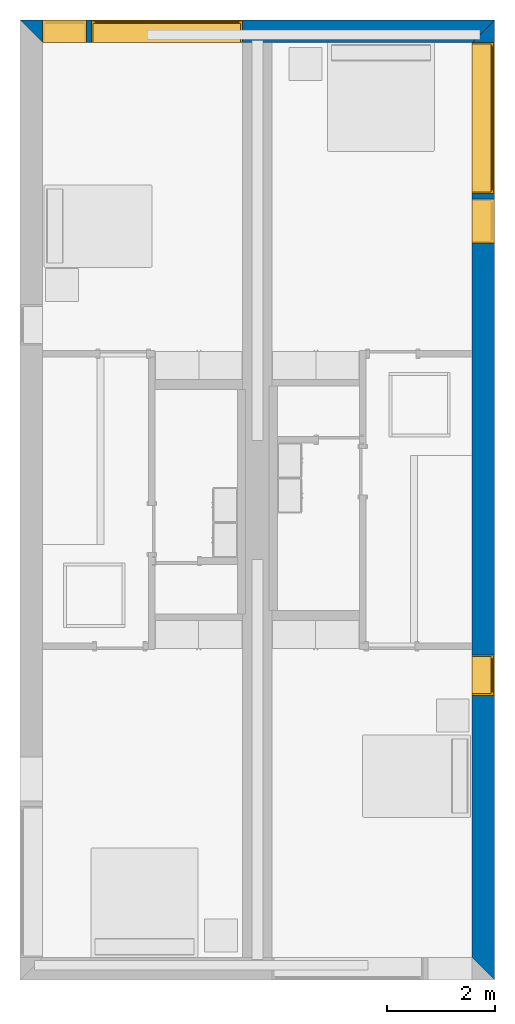
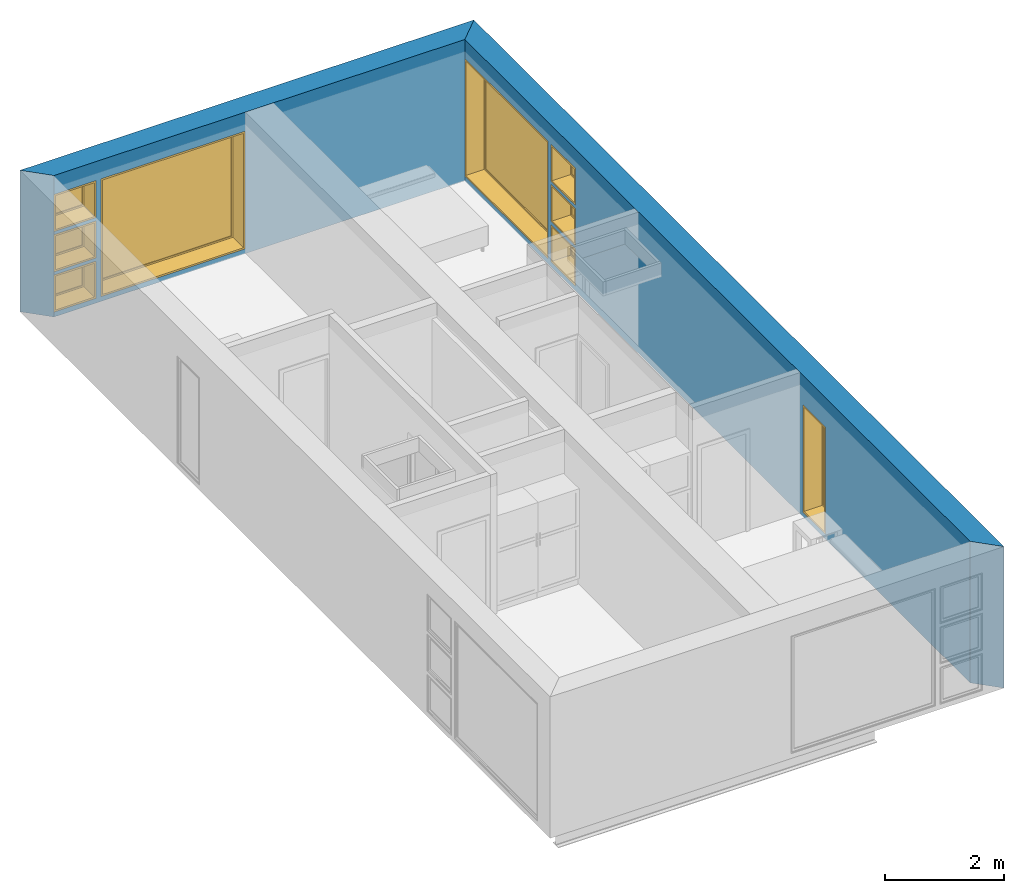
# One storey, part 4 of 10: 9 windows, 2 walls, 12 openings.
"""IFC2X3 building model written with IfcOpenShell, lengths in metres."""

from ifc_helpers import new_model, entity, si_unit, converted_unit, derived_unit, direction, frame, frame_2d, origin, origin_2d_with_axis, place, context, subcontext, project, spatial, polyline, rectangle, outline, extrude, source, transform, mapped, material, material_list, layer, layer_set, layer_usage, type_object, type_shapes, element, fill, save


model = new_model("IFC2X3")

# Units and contexts
model_context = context("Model", 3, precision=1e-05, world=origin(), true_north=direction((6.12303176911189e-17, 1.0)))
body_context = subcontext(model_context, "Body", "Model", "MODEL_VIEW")
ifc_project = project(units=[derived_unit("USERDEFINED", [(si_unit("LENGTHUNIT", "METRE"), -2), (si_unit("TIMEUNIT", "SECOND"), -2), (si_unit("MASSUNIT", "GRAM", prefix="KILO"), 1)]), si_unit("FREQUENCYUNIT", "HERTZ"), si_unit("LENGTHUNIT", "METRE"), si_unit("ILLUMINANCEUNIT", "LUX"), derived_unit("LINEARVELOCITYUNIT", [(si_unit("TIMEUNIT", "SECOND"), -1), (si_unit("LENGTHUNIT", "METRE"), 1)]), si_unit("POWERUNIT", "WATT"), si_unit("LUMINOUSINTENSITYUNIT", "CANDELA"), si_unit("AREAUNIT", "SQUARE_METRE"), si_unit("VOLUMEUNIT", "CUBIC_METRE"), si_unit("ELECTRICVOLTAGEUNIT", "VOLT"), si_unit("PRESSUREUNIT", "PASCAL"), converted_unit("PLANEANGLEUNIT", "DEGREE", entity("IfcRatioMeasure", 0.0174532925199433), si_unit("PLANEANGLEUNIT", "RADIAN"), dimensions=[0, 0, 0, 0, 0, 0, 0]), si_unit("THERMODYNAMICTEMPERATUREUNIT", "DEGREE_CELSIUS"), si_unit("MASSUNIT", "GRAM", prefix="KILO"), derived_unit("VOLUMETRICFLOWRATEUNIT", [(si_unit("LENGTHUNIT", "METRE"), 3), (si_unit("TIMEUNIT", "SECOND"), -1)]), si_unit("TIMEUNIT", "SECOND"), si_unit("LUMINOUSFLUXUNIT", "LUMEN"), derived_unit("USERDEFINED", [(si_unit("LUMINOUSFLUXUNIT", "LUMEN"), 1), (si_unit("TIMEUNIT", "SECOND"), 3), (si_unit("MASSUNIT", "GRAM", prefix="KILO"), -1), (si_unit("LENGTHUNIT", "METRE"), -2)]), si_unit("FORCEUNIT", "NEWTON", prefix="KILO"), si_unit("ELECTRICCURRENTUNIT", "AMPERE"), derived_unit("THERMALTRANSMITTANCEUNIT", [(si_unit("TIMEUNIT", "SECOND"), -3), (si_unit("THERMODYNAMICTEMPERATUREUNIT", "KELVIN"), -1), (si_unit("MASSUNIT", "GRAM", prefix="KILO"), 1)])], contexts=[model_context])

# Site, building, storey
site_placement = place(None, origin())
site = spatial("IfcSite", under=ifc_project, at=site_placement, CompositionType="ELEMENT")
building_placement = place(site_placement, origin())
building = spatial("IfcBuilding", under=site, at=building_placement, CompositionType="ELEMENT")
storey_placement = place(building_placement, frame((0.0, 0.0, 3.10000000000038)))
storey = spatial("IfcBuildingStorey", under=building, at=storey_placement, Name="Level 2", CompositionType="ELEMENT", Elevation=3.10000000000038)

# Wall, openings, windows
ifc_material_1 = material(Name="Masonry - Brick")
ifc_layer_1 = layer(ifc_material_1, 0.092)
ifc_material_2 = material(Name="Misc. Air Layers - Air Space")
ifc_layer_2 = layer(ifc_material_2, 0.025)
ifc_material_3 = material(Name="Insulation / Thermal Barriers - Rigid insulation")
ifc_layer_3 = layer(ifc_material_3, 0.05)
ifc_material_4 = material(Name="Masonry - Concrete Block")
ifc_layer_4 = layer(ifc_material_4, 0.193)
ifc_material_5 = material(Name="Metal - Stud Layer")
ifc_layer_5 = layer(ifc_material_5, 0.041)
ifc_material_6 = material(Name="Plasterboard")
ifc_layer_6 = layer(ifc_material_6, 0.016)
ifc_layer_set = layer_set([ifc_layer_1, ifc_layer_2, ifc_layer_3, ifc_layer_4, ifc_layer_5, ifc_layer_6], Name="Mur de base:Exterior - Brick on Block")
ifc_layer_usage_1 = layer_usage(ifc_layer_set, "AXIS2", "NEGATIVE", 0.2085)
wall_type = type_object("IfcWallType", Name="Mur de base:Exterior - Brick on Block", PredefinedType="STANDARD", material=ifc_layer_set)
wall_1_placement = place(storey_placement, frame((0.0, -0.2085, 0.0)))
wall_1 = element("IfcWallStandardCase", 1, at=wall_1_placement, inside=storey, type_object=wall_type, material=ifc_layer_usage_1, Name="Mur de base:Exterior - Brick on Block", ObjectType="Mur de base:Exterior - Brick on Block", context=body_context, shape_type="SweptSolid", body=[
    extrude(outline(polyline([(8.383, -0.2085), (8.8, 0.2085), (0.0, 0.2085), (0.417000000000001, -0.2085), (4.125, -0.2085), (4.675, -0.2085), (8.383, -0.2085)])), origin(), (0.0, 0.0, 1.0), 2.90000000000001),
])
opening_1_placement = place(wall_1_placement, origin())
element("IfcOpeningElement", 2, at=opening_1_placement, cuts=wall_1, Name="Mur de base:Exterior - Brick on Block", ObjectType="Opening", context=body_context, shape_type="SweptSolid", body=[
    extrude(rectangle(XDim=2.41, YDim=0.417, at=frame_2d((0.0, 0.0), x_axis=(0.0, 1.0))), frame((8.5915, -3.0085, 1.305), z_axis=(0.0, 1.0, 0.0), x_axis=(-1.0, 0.0, 0.0)), (0.0, 0.0, 1.0), 2.8),
])
opening_2_placement = place(wall_1_placement, frame((0.417, -0.2085, 1.75099999999982)))
opening_2 = element("IfcOpeningElement", 3, at=opening_2_placement, cuts=wall_1, Name="M_Fixed:819mm x 759mm:1", ObjectType="Opening", context=body_context, shape_type="SweptSolid", body=[
    extrude(rectangle(XDim=0.758999999999998, YDim=0.819, at=frame_2d((0.379499999999999, 0.4095), x_axis=(1.0, 0.0))), frame((0.0, 0.0, 0.0), z_axis=(0.0, 1.0, 0.0), x_axis=(0.0, 0.0, 1.0)), (0.0, 0.0, 1.0), 0.417),
])
opening_3_placement = place(wall_1_placement, frame((0.417000000000015, -0.208500000000001, 0.925499999999817)))
opening_3 = element("IfcOpeningElement", 4, at=opening_3_placement, cuts=wall_1, Name="M_Casement:819mm x 759mm:1", ObjectType="Opening", context=body_context, shape_type="SweptSolid", body=[
    extrude(rectangle(XDim=0.759000000000001, YDim=0.819, at=frame_2d((0.3795, 0.4095), x_axis=(-1.0, 0.0))), frame((0.0, 0.0, 0.0), z_axis=(0.0, 1.0, 0.0), x_axis=(0.0, 0.0, 1.0)), (0.0, 0.0, 1.0), 0.417),
])
opening_4_placement = place(wall_1_placement, frame((0.417, -0.2085, 0.0999999999998235)))
opening_4 = element("IfcOpeningElement", 5, at=opening_4_placement, cuts=wall_1, Name="M_Fixed:819mm x 759mm:1", ObjectType="Opening", context=body_context, shape_type="SweptSolid", body=[
    extrude(rectangle(XDim=0.758999999999998, YDim=0.819, at=frame_2d((0.379499999999999, 0.4095), x_axis=(1.0, 0.0))), frame((0.0, 0.0, 0.0), z_axis=(0.0, 1.0, 0.0), x_axis=(0.0, 0.0, 1.0)), (0.0, 0.0, 1.0), 0.417),
])
opening_5_placement = place(wall_1_placement, frame((1.325, -0.2085, 0.0999999999998186)))
opening_5 = element("IfcOpeningElement", 6, at=opening_5_placement, cuts=wall_1, Name="M_Fixed:2800mm x 2410mm:1", ObjectType="Opening", context=body_context, shape_type="SweptSolid", body=[
    extrude(rectangle(XDim=2.41, YDim=2.8, at=frame_2d((1.205, 1.4), x_axis=(1.0, 0.0))), frame((0.0, 0.0, 0.0), z_axis=(0.0, 1.0, 0.0), x_axis=(0.0, 0.0, 1.0)), (0.0, 0.0, 1.0), 0.417),
])
ifc_material_7 = material(Name="Glass")
ifc_material_8 = material(Name="Sash")
ifc_material_list_1 = material_list([ifc_material_7, ifc_material_8])
ifc_material_list_2 = material_list([ifc_material_7, ifc_material_8])
window_style_1 = type_object("IfcWindowStyle", Name="2800mm x 2410mm", ConstructionType="OTHER_CONSTRUCTION", OperationType="NOTDEFINED", ParameterTakesPrecedence=False, Sizeable=False, material=ifc_material_list_2)
shared_shape_1 = source(origin(), body_context, "Body", "SweptSolid", [
    extrude(outline(polyline([(-1.4, -1.205), (1.4, -1.205), (1.4, 1.205), (-1.4, 1.205), (-1.4, -1.205)]), holes=[polyline([(-1.368, -1.17299999999998), (-1.368, 1.17300000000002), (1.368, 1.17300000000002), (1.368, -1.17299999999998), (-1.368, -1.17299999999998)])]), frame((1.40000000000001, 0.0, 1.20500000000001), z_axis=(0.0, 1.0, 0.0), x_axis=(1.0, 0.0, 0.0)), (0.0, 0.0, 1.0), 0.353999999999973),
    extrude(rectangle(XDim=0.012, YDim=2.674, at=origin_2d_with_axis()), frame((1.40000000000001, 0.375999999999996, 0.0629999999999851), z_axis=(0.0, 0.0, 1.0), x_axis=(0.0, -1.0, 0.0)), (0.0, 0.0, 1.0), 2.284),
    extrude(outline(polyline([(-1.4, -1.205), (1.4, -1.205), (1.4, 1.205), (-1.4, 1.205), (-1.4, -1.205)]), holes=[polyline([(-1.381, -1.18599999999998), (-1.381, 1.18600000000002), (1.381, 1.18600000000002), (1.381, -1.18599999999998), (-1.381, -1.18599999999998)])]), frame((1.40000000000001, 0.353999999999968, 1.20500000000001), z_axis=(0.0, 1.0, 0.0), x_axis=(1.0, 0.0, 0.0)), (0.0, 0.0, 1.0), 0.0630000000000274),
    extrude(outline(polyline([(-1.381, -1.186), (1.381, -1.186), (1.381, 1.186), (-1.381, 1.186), (-1.381, -1.186)]), holes=[polyline([(-1.337, -1.142), (-1.337, 1.142), (1.337, 1.142), (1.337, -1.142), (-1.337, -1.142)])]), frame((1.40000000000001, 0.353999999999968, 1.20499999999999), z_axis=(0.0, 1.0, 0.0), x_axis=(1.0, 0.0, 0.0)), (0.0, 0.0, 1.0), 0.0440000000000274),
])
type_shapes(window_style_1, [shared_shape_1])
window_1_placement = place(opening_5_placement, origin())
window_1 = element("IfcWindow", 7, at=window_1_placement, inside=storey, type_object=window_style_1, material=ifc_material_list_1, Name="M_Fixed:2800mm x 2410mm", ObjectType="2800mm x 2410mm", OverallHeight=2.41, OverallWidth=2.8, context=body_context, shape_type="MappedRepresentation", body=[
    mapped(shared_shape_1, transform((0.0, 0.0, 0.0), scale=1.0)),
])
fill(opening_5, window_1)
ifc_material_list_3 = material_list([ifc_material_7, ifc_material_8])
ifc_material_list_4 = material_list([ifc_material_7, ifc_material_8])
window_style_2 = type_object("IfcWindowStyle", Name="819mm x 759mm", ConstructionType="OTHER_CONSTRUCTION", OperationType="NOTDEFINED", ParameterTakesPrecedence=False, Sizeable=False, material=ifc_material_list_4)
shared_shape_2 = source(origin(), body_context, "Body", "SweptSolid", [
    extrude(outline(polyline([(-0.4095, -0.379499999999997), (0.4095, -0.379499999999997), (0.4095, 0.379499999999997), (-0.4095, 0.379499999999997), (-0.4095, -0.379499999999997)]), holes=[polyline([(-0.390500000000001, -0.360499999999982), (-0.390500000000001, 0.360500000000023), (0.390499999999999, 0.360500000000023), (0.390499999999999, -0.360499999999982), (-0.390500000000001, -0.360499999999982)])]), frame((0.409500000000009, 0.353999999999971, 0.37950000000001), z_axis=(0.0, 1.0, 0.0), x_axis=(1.0, 0.0, 0.0)), (0.0, 0.0, 1.0), 0.0630000000000274),
    extrude(outline(polyline([(-0.4095, -0.379499999999997), (0.4095, -0.379499999999997), (0.4095, 0.379499999999997), (-0.4095, 0.379499999999997), (-0.4095, -0.379499999999997)]), holes=[polyline([(-0.3775, -0.347499999999983), (-0.3775, 0.347500000000021), (0.3775, 0.347500000000021), (0.3775, -0.347499999999983), (-0.3775, -0.347499999999983)])]), frame((0.40950000000001, 0.0, 0.379500000000009), z_axis=(0.0, 1.0, 0.0), x_axis=(1.0, 0.0, 0.0)), (0.0, 0.0, 1.0), 0.353999999999973),
    extrude(outline(polyline([(-0.3905, -0.360500000000003), (0.3905, -0.360500000000003), (0.3905, 0.360500000000003), (-0.3905, 0.360500000000003), (-0.3905, -0.360500000000003)]), holes=[polyline([(-0.3465, -0.316500000000003), (-0.3465, 0.316500000000004), (0.346499999999997, 0.316500000000004), (0.346499999999997, -0.316500000000003), (-0.3465, -0.316500000000003)])]), frame((0.409500000000008, 0.353999999999971, 0.379499999999989), z_axis=(0.0, 1.0, 0.0), x_axis=(1.0, 0.0, 0.0)), (0.0, 0.0, 1.0), 0.0440000000000274),
    extrude(rectangle(XDim=0.012, YDim=0.692999999999997, at=origin_2d_with_axis()), frame((0.409500000000007, 0.375999999999999, 0.0629999999999851), z_axis=(0.0, 0.0, 1.0), x_axis=(0.0, -1.0, 0.0)), (0.0, 0.0, 1.0), 0.633000000000007),
])
type_shapes(window_style_2, [shared_shape_2])
window_2_placement = place(opening_4_placement, origin())
window_2 = element("IfcWindow", 8, at=window_2_placement, inside=storey, type_object=window_style_2, material=ifc_material_list_3, Name="M_Fixed:819mm x 759mm", ObjectType="819mm x 759mm", OverallHeight=0.758999999999998, OverallWidth=0.819, context=body_context, shape_type="MappedRepresentation", body=[
    mapped(shared_shape_2, transform((0.0, 0.0, 0.0), scale=1.0)),
])
fill(opening_4, window_2)
ifc_material_list_5 = material_list([ifc_material_7, ifc_material_8])
window_3_placement = place(opening_2_placement, origin())
window_3 = element("IfcWindow", 9, at=window_3_placement, inside=storey, type_object=window_style_2, material=ifc_material_list_5, Name="M_Fixed:819mm x 759mm", ObjectType="819mm x 759mm", OverallHeight=0.758999999999999, OverallWidth=0.819, context=body_context, shape_type="MappedRepresentation", body=[
    mapped(shared_shape_2, transform((0.0, 0.0, 0.0), scale=1.0)),
])
fill(opening_2, window_3)
ifc_material_9 = material(Name="Trim")
ifc_material_list_6 = material_list([ifc_material_7, ifc_material_8, ifc_material_9])
ifc_material_list_7 = material_list([ifc_material_7, ifc_material_8, ifc_material_9])
window_style_3 = type_object("IfcWindowStyle", Name="819mm x 759mm", ConstructionType="OTHER_CONSTRUCTION", OperationType="NOTDEFINED", ParameterTakesPrecedence=False, Sizeable=False, material=ifc_material_list_7)
shared_shape_3 = source(origin(), body_context, "Body", "SweptSolid", [
    extrude(outline(polyline([(-0.390449999999999, -0.360450000000001), (0.390449999999999, -0.360450000000001), (0.390449999999999, 0.360450000000001), (-0.390449999999999, 0.360450000000001), (-0.390449999999999, -0.360450000000001)]), holes=[polyline([(-0.345999999999998, -0.316000000000002), (-0.345999999999998, 0.316000000000003), (0.346, 0.316000000000003), (0.346, -0.316000000000002), (-0.345999999999998, -0.316000000000002)])]), frame((0.409499999999999, 0.35355, 0.379500000000007), z_axis=(0.0, 1.0, 0.0), x_axis=(1.0, 0.0, 0.0)), (0.0, 0.0, 1.0), 0.04445),
    extrude(outline(polyline([(-0.379500000000002, -0.409499999999999), (0.379500000000002, -0.409499999999999), (0.379500000000002, 0.409499999999999), (-0.379500000000002, 0.409499999999999), (-0.379500000000002, -0.409499999999999)]), holes=[polyline([(-0.360450000000002, -0.390449999999999), (-0.360450000000002, 0.39045), (0.360450000000002, 0.39045), (0.360450000000002, -0.390449999999999), (-0.360450000000002, -0.390449999999999)])]), frame((0.4095, 0.35355, 0.379500000000007), z_axis=(0.0, 1.0, 0.0), x_axis=(0.0, 0.0, -1.0)), (0.0, 0.0, 1.0), 0.06345),
    extrude(rectangle(XDim=0.0127, YDim=0.691999999999998, at=frame_2d((-1.69135538907739e-17, 0.0), x_axis=(1.0, 0.0))), frame((0.4095, 0.375775, 0.063500000000004), z_axis=(0.0, 0.0, 1.0), x_axis=(0.0, 1.0, 0.0)), (0.0, 0.0, 1.0), 0.632000000000004),
    extrude(outline(polyline([(-0.409499999999999, -0.379500000000001), (0.409499999999999, -0.379500000000001), (0.409499999999999, 0.379500000000001), (-0.409499999999999, 0.379500000000001), (-0.409499999999999, -0.379500000000001)]), holes=[polyline([(-0.37775, -0.34775), (-0.37775, 0.347750000000001), (0.377749999999998, 0.347750000000001), (0.377749999999998, -0.34775), (-0.37775, -0.34775)])]), frame((0.409500000000001, 0.0, 0.379500000000008), z_axis=(0.0, 1.0, 0.0), x_axis=(1.0, 0.0, 0.0)), (0.0, 0.0, 1.0), 0.35355),
])
type_shapes(window_style_3, [shared_shape_3])
window_4_placement = place(opening_3_placement, origin())
window_4 = element("IfcWindow", 10, at=window_4_placement, inside=storey, type_object=window_style_3, material=ifc_material_list_6, Name="M_Casement:819mm x 759mm", ObjectType="819mm x 759mm", OverallHeight=0.759000000000001, OverallWidth=0.819, context=body_context, shape_type="MappedRepresentation", body=[
    mapped(shared_shape_3, transform((0.0, 0.0, 0.0), scale=1.0)),
])
fill(opening_3, window_4)

ifc_layer_usage_2 = layer_usage(ifc_layer_set, "AXIS2", "NEGATIVE", 0.2085)
wall_2_placement = place(storey_placement, frame((8.5915, 0.0, 0.0), z_axis=(0.0, 0.0, 1.0), x_axis=(0.0, -1.0, 0.0)))
wall_2 = element("IfcWallStandardCase", 11, at=wall_2_placement, inside=storey, type_object=wall_type, material=ifc_layer_usage_2, Name="Mur de base:Exterior - Brick on Block", ObjectType="Mur de base:Exterior - Brick on Block", context=body_context, shape_type="SweptSolid", body=[
    extrude(outline(polyline([(17.383, -0.2085), (17.8, 0.2085), (0.0, 0.2085), (0.416999999999999, -0.208500000000001), (6.12599999999998, -0.2085), (6.24999999999998, -0.2085), (17.383, -0.2085)])), origin(), (0.0, 0.0, 1.0), 2.90000000000001),
])
opening_6_placement = place(wall_2_placement, origin())
element("IfcOpeningElement", 12, at=opening_6_placement, cuts=wall_2, Name="Mur de base:Exterior - Brick on Block", ObjectType="Opening", context=body_context, shape_type="SweptSolid", body=[
    extrude(rectangle(XDim=0.758999999999998, YDim=0.417, at=frame_2d((0.0, 2.77555756156289e-16), x_axis=(0.0, 1.0))), frame((17.5915, -1.0275, 2.1305), z_axis=(0.0, 1.0, 0.0), x_axis=(-1.0, 0.0, 0.0)), (0.0, 0.0, 1.0), 0.819),
])
opening_7_placement = place(wall_2_placement, origin())
element("IfcOpeningElement", 13, at=opening_7_placement, cuts=wall_2, Name="Mur de base:Exterior - Brick on Block", ObjectType="Opening", context=body_context, shape_type="SweptSolid", body=[
    extrude(rectangle(XDim=0.758999999999998, YDim=0.417, at=frame_2d((0.0, 2.77555756156289e-16), x_axis=(0.0, 1.0))), frame((17.5915, -1.0275, 0.479500000000005), z_axis=(0.0, 1.0, 0.0), x_axis=(-1.0, 0.0, 0.0)), (0.0, 0.0, 1.0), 0.819),
])
opening_8_placement = place(wall_2_placement, frame((0.417000000000026, -0.208499999999995, 0.0999999999998186)))
opening_8 = element("IfcOpeningElement", 14, at=opening_8_placement, cuts=wall_2, Name="M_Fixed:2800mm x 2410mm:1", ObjectType="Opening", context=body_context, shape_type="SweptSolid", body=[
    extrude(rectangle(XDim=2.41, YDim=2.8, at=frame_2d((1.205, 1.4), x_axis=(1.0, 0.0))), frame((0.0, 0.0, 0.0), z_axis=(0.0, 1.0, 0.0), x_axis=(0.0, 0.0, 1.0)), (0.0, 0.0, 1.0), 0.417),
])
opening_9_placement = place(wall_2_placement, frame((11.774, -0.208500000000017, 0.0999999999998186)))
opening_9 = element("IfcOpeningElement", 15, at=opening_9_placement, cuts=wall_2, Name="M_Fixed:750mm x 2200mm:1", ObjectType="Opening", context=body_context, shape_type="SweptSolid", body=[
    extrude(rectangle(XDim=2.2, YDim=0.75, at=frame_2d((1.1, 0.374999999999999), x_axis=(1.0, 0.0))), frame((0.0, 0.0, 0.0), z_axis=(0.0, 1.0, 0.0), x_axis=(0.0, 0.0, 1.0)), (0.0, 0.0, 1.0), 0.417),
])
opening_10_placement = place(wall_2_placement, frame((3.31700000000003, -0.208500000000004, 1.75099999999982)))
opening_10 = element("IfcOpeningElement", 16, at=opening_10_placement, cuts=wall_2, Name="M_Fixed:819mm x 759mm:1", ObjectType="Opening", context=body_context, shape_type="SweptSolid", body=[
    extrude(rectangle(XDim=0.758999999999998, YDim=0.819, at=frame_2d((0.379499999999999, 0.4095), x_axis=(1.0, 0.0))), frame((0.0, 0.0, 0.0), z_axis=(0.0, 1.0, 0.0), x_axis=(0.0, 0.0, 1.0)), (0.0, 0.0, 1.0), 0.417),
])
opening_11_placement = place(wall_2_placement, frame((3.31700000000004, -0.208500000000005, 0.925499999999818)))
opening_11 = element("IfcOpeningElement", 17, at=opening_11_placement, cuts=wall_2, Name="M_Casement:819mm x 759mm:1", ObjectType="Opening", context=body_context, shape_type="SweptSolid", body=[
    extrude(rectangle(XDim=0.759000000000001, YDim=0.819, at=frame_2d((0.3795, 0.4095), x_axis=(-1.0, 0.0))), frame((0.0, 0.0, 0.0), z_axis=(0.0, 1.0, 0.0), x_axis=(0.0, 0.0, 1.0)), (0.0, 0.0, 1.0), 0.417),
])
opening_12_placement = place(wall_2_placement, frame((3.31700000000003, -0.208500000000004, 0.0999999999998186)))
opening_12 = element("IfcOpeningElement", 18, at=opening_12_placement, cuts=wall_2, Name="M_Fixed:819mm x 759mm:1", ObjectType="Opening", context=body_context, shape_type="SweptSolid", body=[
    extrude(rectangle(XDim=0.758999999999998, YDim=0.819, at=frame_2d((0.379499999999999, 0.4095), x_axis=(1.0, 0.0))), frame((0.0, 0.0, 0.0), z_axis=(0.0, 1.0, 0.0), x_axis=(0.0, 0.0, 1.0)), (0.0, 0.0, 1.0), 0.417),
])
ifc_material_list_8 = material_list([ifc_material_7, ifc_material_8])
ifc_material_list_9 = material_list([ifc_material_7, ifc_material_8])
window_style_4 = type_object("IfcWindowStyle", Name="750mm x 2200mm", ConstructionType="OTHER_CONSTRUCTION", OperationType="NOTDEFINED", ParameterTakesPrecedence=False, Sizeable=False, material=ifc_material_list_9)
shared_shape_4 = source(origin(), body_context, "Body", "SweptSolid", [
    extrude(outline(polyline([(-0.356, -1.081), (0.356, -1.081), (0.356, 1.081), (-0.356, 1.081), (-0.356, -1.081)]), holes=[polyline([(-0.312, -1.037), (-0.312, 1.037), (0.311999999999997, 1.037), (0.311999999999997, -1.037), (-0.312, -1.037)])]), frame((0.375000000000008, 0.353999999999972, 1.09999999999999), z_axis=(0.0, 1.0, 0.0), x_axis=(1.0, 0.0, 0.0)), (0.0, 0.0, 1.0), 0.0440000000000274),
    extrude(rectangle(XDim=0.012, YDim=0.623999999999997, at=origin_2d_with_axis()), frame((0.375000000000007, 0.375999999999999, 0.0629999999999851), z_axis=(0.0, 0.0, 1.0), x_axis=(0.0, -1.0, 0.0)), (0.0, 0.0, 1.0), 2.07400000000001),
    extrude(outline(polyline([(-0.375, -1.1), (0.375, -1.1), (0.375, 1.1), (-0.375, 1.1), (-0.375, -1.1)]), holes=[polyline([(-0.356000000000001, -1.08099999999998), (-0.356000000000001, 1.08100000000002), (0.355999999999999, 1.08100000000002), (0.355999999999999, -1.08099999999998), (-0.356000000000001, -1.08099999999998)])]), frame((0.375000000000009, 0.353999999999972, 1.10000000000001), z_axis=(0.0, 1.0, 0.0), x_axis=(1.0, 0.0, 0.0)), (0.0, 0.0, 1.0), 0.0630000000000274),
    extrude(outline(polyline([(-0.375, -1.1), (0.375, -1.1), (0.375, 1.1), (-0.375, 1.1), (-0.375, -1.1)]), holes=[polyline([(-0.343, -1.06799999999998), (-0.343, 1.06800000000002), (0.343, 1.06800000000002), (0.343, -1.06799999999998), (-0.343, -1.06799999999998)])]), frame((0.37500000000001, 0.0, 1.10000000000001), z_axis=(0.0, 1.0, 0.0), x_axis=(1.0, 0.0, 0.0)), (0.0, 0.0, 1.0), 0.353999999999973),
])
type_shapes(window_style_4, [shared_shape_4])
window_5_placement = place(opening_9_placement, origin())
window_5 = element("IfcWindow", 19, at=window_5_placement, inside=storey, type_object=window_style_4, material=ifc_material_list_8, Name="M_Fixed:750mm x 2200mm", ObjectType="750mm x 2200mm", OverallHeight=2.2, OverallWidth=0.749999999999998, context=body_context, shape_type="MappedRepresentation", body=[
    mapped(shared_shape_4, transform((0.0, 0.0, 0.0), scale=1.0)),
])
fill(opening_9, window_5)
ifc_material_list_10 = material_list([ifc_material_7, ifc_material_8])
window_6_placement = place(opening_8_placement, origin())
window_6 = element("IfcWindow", 20, at=window_6_placement, inside=storey, type_object=window_style_1, material=ifc_material_list_10, Name="M_Fixed:2800mm x 2410mm", ObjectType="2800mm x 2410mm", OverallHeight=2.41, OverallWidth=2.8, context=body_context, shape_type="MappedRepresentation", body=[
    mapped(shared_shape_1, transform((0.0, 0.0, 0.0), scale=1.0)),
])
fill(opening_8, window_6)
ifc_material_list_11 = material_list([ifc_material_7, ifc_material_8])
window_7_placement = place(opening_10_placement, origin())
window_7 = element("IfcWindow", 21, at=window_7_placement, inside=storey, type_object=window_style_2, material=ifc_material_list_11, Name="M_Fixed:819mm x 759mm", ObjectType="819mm x 759mm", OverallHeight=0.758999999999998, OverallWidth=0.819, context=body_context, shape_type="MappedRepresentation", body=[
    mapped(shared_shape_2, transform((0.0, 0.0, 0.0), scale=1.0)),
])
fill(opening_10, window_7)
ifc_material_list_12 = material_list([ifc_material_7, ifc_material_8])
window_8_placement = place(opening_12_placement, origin())
window_8 = element("IfcWindow", 22, at=window_8_placement, inside=storey, type_object=window_style_2, material=ifc_material_list_12, Name="M_Fixed:819mm x 759mm", ObjectType="819mm x 759mm", OverallHeight=0.758999999999999, OverallWidth=0.819, context=body_context, shape_type="MappedRepresentation", body=[
    mapped(shared_shape_2, transform((0.0, 0.0, 0.0), scale=1.0)),
])
fill(opening_12, window_8)
ifc_material_list_13 = material_list([ifc_material_7, ifc_material_8, ifc_material_9])
window_9_placement = place(opening_11_placement, origin())
window_9 = element("IfcWindow", 23, at=window_9_placement, inside=storey, type_object=window_style_3, material=ifc_material_list_13, Name="M_Casement:819mm x 759mm", ObjectType="819mm x 759mm", OverallHeight=0.759000000000001, OverallWidth=0.819, context=body_context, shape_type="MappedRepresentation", body=[
    mapped(shared_shape_3, transform((0.0, 0.0, 0.0), scale=1.0)),
])
fill(opening_11, window_9)

save(model, "model.ifc")
